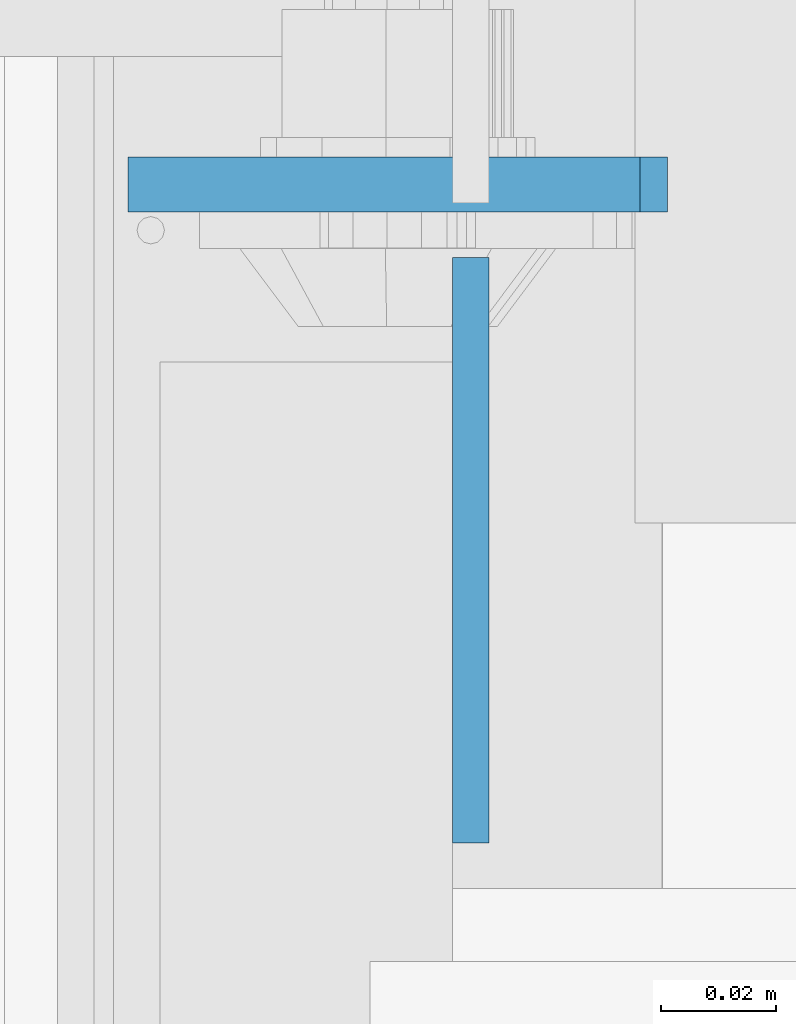
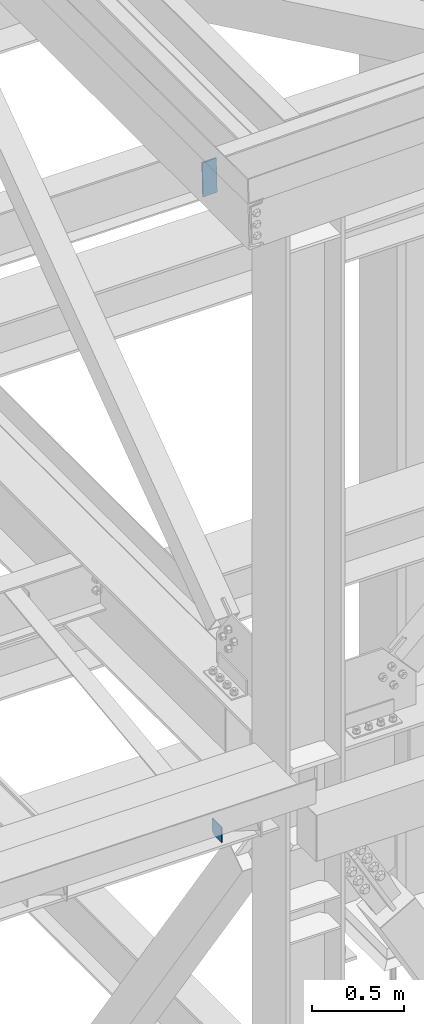
# One storey, part 3097 of 3843: 2 plates, 2 elements without a shape of their own.
"""IFC2X3 building model written with IfcOpenShell, lengths in millimetres."""

from ifc_helpers import new_model, si_unit, frame, origin_with_axes, place, context, subcontext, project, spatial, faceted_brep, material, type_object, element, aggregate, save


model = new_model("IFC2X3")

# Units and contexts
model_context = context("Model", 3, precision=1e-05, world=origin_with_axes())
body_context = subcontext(model_context, "Body", "Model", "MODEL_VIEW")
ifc_project = project(units=[si_unit("LENGTHUNIT", "METRE", prefix="MILLI"), si_unit("AREAUNIT", "SQUARE_METRE"), si_unit("VOLUMEUNIT", "CUBIC_METRE"), si_unit("MASSUNIT", "GRAM", prefix="KILO"), si_unit("TIMEUNIT", "SECOND"), si_unit("PLANEANGLEUNIT", "RADIAN"), si_unit("SOLIDANGLEUNIT", "STERADIAN"), si_unit("THERMODYNAMICTEMPERATUREUNIT", "DEGREE_CELSIUS"), si_unit("LUMINOUSINTENSITYUNIT", "LUMEN")], contexts=[model_context])

# Site, building, storey
site_placement = place(None, origin_with_axes())
site = spatial("IfcSite", under=ifc_project, at=site_placement, CompositionType="ELEMENT")
building_placement = place(site_placement, origin_with_axes())
building = spatial("IfcBuilding", under=site, at=building_placement, Name="Undefined", CompositionType="ELEMENT")
storey_placement = place(building_placement, origin_with_axes())
storey = spatial("IfcBuildingStorey", under=building, at=storey_placement, Name="Undefined", CompositionType="ELEMENT", Elevation=0.0)

# Assembly, plate
assembly_1_placement = place(storey_placement, origin_with_axes())
assembly_1 = element("IfcElementAssembly", 1, at=assembly_1_placement, inside=storey, Name="CHANNEL", AssemblyPlace="NOTDEFINED", PredefinedType="RIGID_FRAME")
ifc_material = material(Name="STEEL/A572-50")
plate_type_1 = type_object("IfcPlateType", PredefinedType="NOTDEFINED")
plate_1_placement = place(assembly_1_placement, frame((76411.9416340751, 15006.6375, 46534.2876976318), z_axis=(0.999776270257024, 0.0, 0.0211520550054619), x_axis=(0.0211520550054438, 0.0, -0.999776270257025)))
plate_1 = element("IfcPlate", 2, at=plate_1_placement, type_object=plate_type_1, material=ifc_material, Name="PLATE", context=body_context, shape_type="Brep", body=[
    faceted_brep([(0.0, -4.76249999999709, 0.0), (0.0, -4.76249999999709, 88.9000015258789), (0.0, 4.76249999999709, 88.9000015258789), (0.0, 4.76249999999709, 0.0), (228.600006102781, -4.7625000004191, 88.9000015257589), (228.600006102781, 4.76249999954598, 88.9000015257443), (228.600006103079, -4.7625000004482, 7.27595761418343e-12), (228.600006103079, 4.76249999954598, -7.27595761418343e-12)], [[[0, 1, 2, 3]], [[1, 4, 5, 2]], [[4, 6, 7, 5]], [[6, 0, 3, 7]], [[5, 7, 3, 2]], [[6, 4, 1, 0]]]),
])
aggregate(assembly_1, [plate_1])

assembly_2_placement = place(storey_placement, origin_with_axes())
assembly_2 = element("IfcElementAssembly", 3, at=assembly_2_placement, inside=storey, Name="BEAM", AssemblyPlace="NOTDEFINED", PredefinedType="RIGID_FRAME")
plate_type_2 = type_object("IfcPlateType", PredefinedType="NOTDEFINED")
plate_2_placement = place(assembly_2_placement, frame((76471.4625, 14892.3375, 42070.3375), z_axis=(0.0, 0.0, 1.0), x_axis=(0.0, 1.0, 0.0)))
plate_2 = element("IfcPlate", 4, at=plate_2_placement, type_object=plate_type_2, material=ifc_material, Name="PLATE", context=body_context, shape_type="Brep", body=[
    faceted_brep([(0.0, -3.17499999999927, 0.0), (0.0, -3.17499999999927, 101.600000000006), (0.0, 3.17499999999927, 101.600000000006), (0.0, 3.17499999999927, 0.0), (101.6, -3.17500000000291, 101.599999999999), (101.6, 3.17500000000291, 101.599999999999), (101.6, -3.17500000000291, 19.0499992370605), (101.6, 3.17500000000291, 19.0499992370605), (82.5500007629398, -3.17500000000291, 0.0), (82.5500007629398, 3.17500000000291, 0.0)], [[[0, 1, 2, 3]], [[1, 4, 5, 2]], [[4, 6, 7, 5]], [[6, 8, 9, 7]], [[8, 0, 3, 9]], [[5, 7, 9, 3, 2]], [[8, 6, 4, 1, 0]]]),
])
aggregate(assembly_2, [plate_2])

save(model, "model.ifc")
